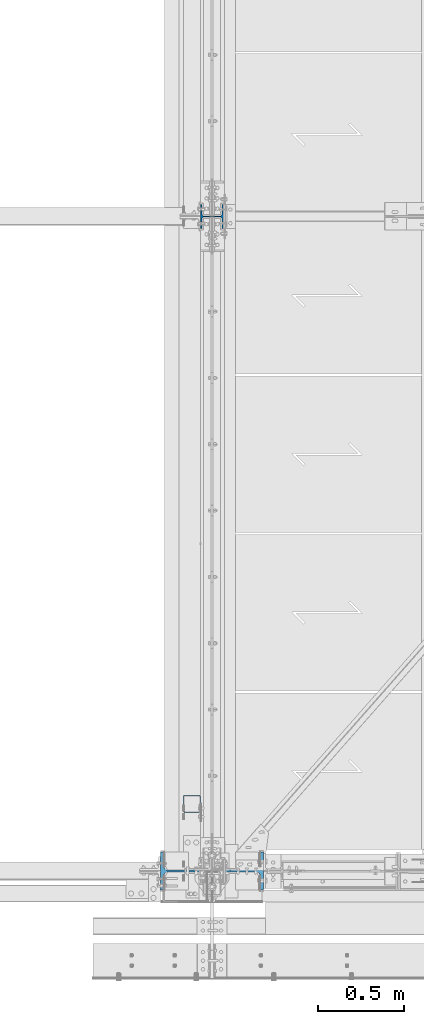
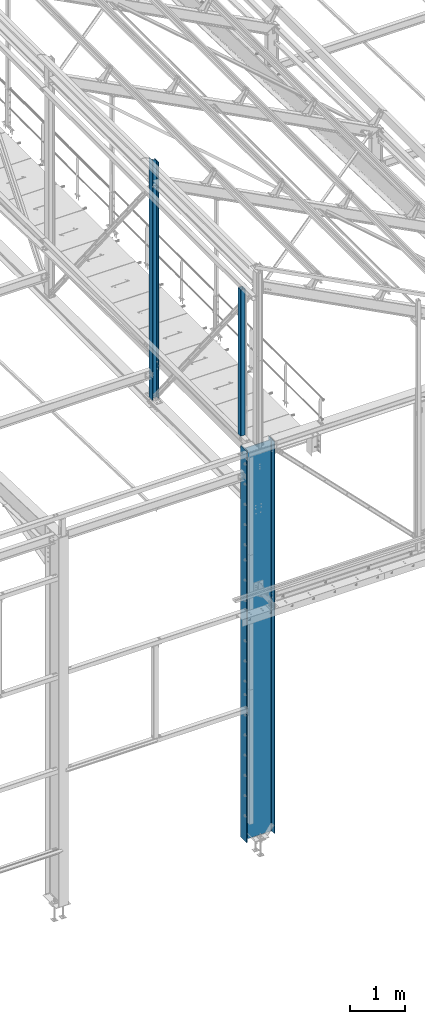
# One storey, part 3 of 496: 3 columns, 3 elements without a shape of their own.
"""IFC2X3 building model written with IfcOpenShell, lengths in millimetres."""

import ifcopenshell
import ifcopenshell.guid

model = None  # the IFC model being written
_history = None  # IfcOwnerHistory: only IFC2X3 demands one
_inside = {}  # id of a spatial element -> (the spatial element, [elements in it])
_under = {}  # id of a project, library or spatial element -> (it, [spatial elements below it])
_declared = {}  # id of a project -> (the project, [libraries it declares])
_typed = {}  # id of a type object -> (the type object, [elements of that type])
_made_of = {}  # id of a material, layer set ... -> (it, [elements and type objects made of it])


def new_model(schema):
    """Start an empty IFC model of exactly this schema.

    Asked for "IFC4X3", IfcOpenShell would pick the latest addendum, in which some entities
    have other attributes; the version numbers below select the first issue.
    IFC2X3 requires an IfcOwnerHistory on every rooted entity: one is made here for all.
    """
    global model, _history
    if schema == "IFC4X3":
        model = ifcopenshell.file(schema_version=(4, 3, 0, 0))
    else:
        model = ifcopenshell.file(schema=schema)
    _inside.clear()
    _under.clear()
    _declared.clear()
    _typed.clear()
    _made_of.clear()
    _history = None
    if model.schema == "IFC2X3":
        org = make("IfcOrganization", Name="unknown")
        user = make(
            "IfcPersonAndOrganization",
            ThePerson=make("IfcPerson", FamilyName="unknown"),
            TheOrganization=org,
        )
        app = make(
            "IfcApplication",
            ApplicationDeveloper=org,
            Version="unknown",
            ApplicationFullName="unknown",
            ApplicationIdentifier="unknown",
        )
        _history = make(
            "IfcOwnerHistory",
            OwningUser=user,
            OwningApplication=app,
            ChangeAction="ADDED",
            CreationDate=0,
        )
    return model


def make(cls, **values):
    """One entity of the class cls with the attributes given. An attribute that is None is left unset."""
    return model.create_entity(
        cls, **{name: value for name, value in values.items() if value is not None}
    )


def rooted(cls, **values):
    """An entity with a GlobalId (a new one), such as an element, a storey or a relation."""
    return make(cls, GlobalId=ifcopenshell.guid.new(), OwnerHistory=_history, **values)


def si_unit(unit_type, name, prefix=None):
    """IfcSIUnit, for example si_unit("LENGTHUNIT", "METRE", prefix="MILLI")."""
    return make("IfcSIUnit", UnitType=unit_type, Prefix=prefix, Name=name)


def assignment(units):
    """IfcUnitAssignment: the units of a project."""
    return None if units is None else make("IfcUnitAssignment", Units=units)


def point(xyz):
    """IfcCartesianPoint."""
    return None if xyz is None else make("IfcCartesianPoint", Coordinates=xyz)


def direction(xyz):
    """IfcDirection."""
    return None if xyz is None else make("IfcDirection", DirectionRatios=xyz)


def frame(location, z_axis=None, x_axis=None):
    """IfcAxis2Placement3D, a coordinate frame: its origin and axes. An axis left out is left unset."""
    return make(
        "IfcAxis2Placement3D",
        Location=point(location),
        Axis=direction(z_axis),
        RefDirection=direction(x_axis),
    )


def frame_2d(location, x_axis=None):
    """IfcAxis2Placement2D, a coordinate frame in the plane: its origin and x axis."""
    return make(
        "IfcAxis2Placement2D", Location=point(location), RefDirection=direction(x_axis)
    )


def origin_with_axes():
    """The frame at (0, 0, 0) with the z axis (0, 0, 1) and the x axis (1, 0, 0) written out."""
    return frame((0.0, 0.0, 0.0), z_axis=(0.0, 0.0, 1.0), x_axis=(1.0, 0.0, 0.0))


def origin_2d_with_axis():
    """The frame at (0, 0) in the plane with the x axis (1, 0) written out."""
    return frame_2d((0.0, 0.0), x_axis=(1.0, 0.0))


def place(relative_to, where):
    """IfcLocalPlacement: puts the frame where relative to a parent placement (None: the world)."""
    return make(
        "IfcLocalPlacement", PlacementRelTo=relative_to, RelativePlacement=where
    )


def context(
    kind, dimensions, precision=None, world=None, true_north=None, identifier=None
):
    """IfcGeometricRepresentationContext, for example the 3D "Model" context."""
    return make(
        "IfcGeometricRepresentationContext",
        ContextIdentifier=identifier,
        ContextType=kind,
        CoordinateSpaceDimension=dimensions,
        Precision=precision,
        WorldCoordinateSystem=world,
        TrueNorth=true_north,
    )


def subcontext(parent, identifier, kind, view, scale=None):
    """IfcGeometricRepresentationSubContext, for example "Body" below "Model"."""
    return make(
        "IfcGeometricRepresentationSubContext",
        ContextIdentifier=identifier,
        ContextType=kind,
        ParentContext=parent,
        TargetScale=scale,
        TargetView=view,
    )


def project(units=None, contexts=None):
    """IfcProject with its units and contexts."""
    return rooted(
        "IfcProject",
        Name="project",
        RepresentationContexts=contexts,
        UnitsInContext=assignment(units),
    )


def spatial(cls, under=None, at=None, **own):
    """A site, building, storey or space (cls), placed at a placement, below another one or the project."""
    s = rooted(cls, ObjectPlacement=at, **own)
    if under is not None:
        _under.setdefault(under.id(), (under, []))[1].append(s)
    return s


def profile(cls, at=None, kind="AREA", **sizes):
    """A parametric profile (cls). Its sizes go by their IFC names, for example OverallWidth=200.0."""
    return make(cls, ProfileType=kind, Position=at, **sizes)


def hollow_rectangle(**sizes):
    """IfcRectangleHollowProfileDef."""
    return profile("IfcRectangleHollowProfileDef", **sizes)


def i_section(**sizes):
    """IfcIShapeProfileDef."""
    return profile("IfcIShapeProfileDef", **sizes)


def extrude(swept, where, along, depth):
    """IfcExtrudedAreaSolid: the profile swept, set in the frame where, extruded along a direction by depth."""
    return make(
        "IfcExtrudedAreaSolid",
        SweptArea=swept,
        Position=where,
        ExtrudedDirection=direction(along),
        Depth=depth,
    )


def clip(a, b, op="DIFFERENCE"):
    """IfcBooleanClippingResult: the solid a cut by the half space b."""
    return make(
        "IfcBooleanClippingResult", Operator=op, FirstOperand=a, SecondOperand=b
    )


def halfspace(plane, agree):
    """IfcHalfSpaceSolid: all space on one side of the plane z = 0 of the frame plane."""
    return make(
        "IfcHalfSpaceSolid",
        BaseSurface=make("IfcPlane", Position=plane),
        AgreementFlag=agree,
    )


def shape(context_of_items, identifier, shape_type, items):
    """IfcShapeRepresentation: the items that make up one representation, for example the "Body"."""
    return make(
        "IfcShapeRepresentation",
        ContextOfItems=context_of_items,
        RepresentationIdentifier=identifier,
        RepresentationType=shape_type,
        Items=items,
    )


def material(Name=None, Category=None):
    """IfcMaterial."""
    return make("IfcMaterial", Name=Name, Category=Category)


def made_of(thing, what):
    """Note that an element or type object is made of a material, layer set ...; save() writes the relation."""
    if what is not None:
        _made_of.setdefault(what.id(), (what, []))[1].append(thing)
    return thing


def type_object(cls, material=None, **own):
    """A type object (cls), such as IfcWallType, which elements share."""
    return made_of(rooted(cls, **own), material)


def element(
    cls,
    number,
    at=None,
    inside=None,
    cuts=None,
    type_object=None,
    material=None,
    context=None,
    identifier="Body",
    shape_type=None,
    held_by="IfcProductDefinitionShape",
    body=None,
    shapes=None,
    **own,
):
    """One element of the class cls, such as IfcWall. Its Tag is "e" and its number.

    at: its placement. inside: the storey or other place that contains it. cuts: it is an
    opening in that element (IfcRelVoidsElement). A single representation is given by context,
    identifier, shape_type and body (its items); several are given by shapes. held_by: the class
    of the entity that holds the representations. save() writes the other relations.
    """
    e = rooted(cls, Tag="e%d" % number, ObjectPlacement=at, **own)
    if body is not None:
        shapes = [shape(context, identifier, shape_type, body)]
    if shapes is not None:
        e.Representation = make(held_by, Representations=shapes)
    if inside is not None:
        _inside.setdefault(inside.id(), (inside, []))[1].append(e)
    if cuts is not None:
        rooted(
            "IfcRelVoidsElement", RelatingBuildingElement=cuts, RelatedOpeningElement=e
        )
    if type_object is not None:
        _typed.setdefault(type_object.id(), (type_object, []))[1].append(e)
    return made_of(e, material)


def aggregate(whole, parts):
    """IfcRelAggregates: a whole, such as a stair, and the parts it consists of."""
    return rooted("IfcRelAggregates", RelatingObject=whole, RelatedObjects=parts)


def save(model, path):
    """Write the relations noted so far, then the file.

    IfcRelAggregates (storeys below a building ...), IfcRelContainedInSpatialStructure (elements
    in a storey), IfcRelDefinesByType, IfcRelAssociatesMaterial and IfcRelDeclares: one each for
    every whole, place, type object, material and project.
    """
    for whole, parts in _under.values():
        aggregate(whole, parts)
    for where, things in _inside.values():
        rooted(
            "IfcRelContainedInSpatialStructure",
            RelatedElements=things,
            RelatingStructure=where,
        )
    for kind, things in _typed.values():
        rooted("IfcRelDefinesByType", RelatedObjects=things, RelatingType=kind)
    for what, things in _made_of.values():
        rooted("IfcRelAssociatesMaterial", RelatedObjects=things, RelatingMaterial=what)
    for by, libraries in _declared.values():
        rooted("IfcRelDeclares", RelatingContext=by, RelatedDefinitions=libraries)
    model.write(path)


model = new_model("IFC2X3")

# Units and contexts
model_context = context("Model", 3, precision=1e-05, world=origin_with_axes())
body_context = subcontext(model_context, "Body", "Model", "MODEL_VIEW")
ifc_project = project(units=[si_unit("LENGTHUNIT", "METRE", prefix="MILLI"), si_unit("AREAUNIT", "SQUARE_METRE"), si_unit("VOLUMEUNIT", "CUBIC_METRE"), si_unit("MASSUNIT", "GRAM", prefix="KILO"), si_unit("TIMEUNIT", "SECOND"), si_unit("PLANEANGLEUNIT", "RADIAN"), si_unit("SOLIDANGLEUNIT", "STERADIAN"), si_unit("THERMODYNAMICTEMPERATUREUNIT", "DEGREE_CELSIUS"), si_unit("LUMINOUSINTENSITYUNIT", "LUMEN")], contexts=[model_context])

# Site, building, storey
site_placement = place(None, origin_with_axes())
site = spatial("IfcSite", under=ifc_project, at=site_placement, CompositionType="ELEMENT")
building_placement = place(site_placement, origin_with_axes())
building = spatial("IfcBuilding", under=site, at=building_placement, Name="Undefined", CompositionType="ELEMENT")
storey_placement = place(building_placement, origin_with_axes())
storey = spatial("IfcBuildingStorey", under=building, at=storey_placement, Name="Undefined", CompositionType="ELEMENT", Elevation=0.0)

# Assembly, column
assembly_1_placement = place(storey_placement, origin_with_axes())
assembly_1 = element("IfcElementAssembly", 1, at=assembly_1_placement, inside=storey, Name="MONTANT", AssemblyPlace="NOTDEFINED", PredefinedType="NOTDEFINED")
ifc_material_1 = material(Name="Undefined/S235-E24")
column_type_1 = type_object("IfcColumnType", PredefinedType="NOTDEFINED")
column_1_placement = place(assembly_1_placement, frame((12563.5001162733, 389.9999987911, 8555.00000000001), z_axis=(0.0, 0.0, 1.0), x_axis=(0.0, -1.0, 0.0)))
column_1 = element("IfcColumn", 2, at=column_1_placement, type_object=column_type_1, material=ifc_material_1, Name="MONTANT", context=body_context, shape_type="SweptSolid", body=[
    extrude(hollow_rectangle(XDim=100.0, YDim=100.0, WallThickness=4.0, InnerFilletRadius=4.0, OuterFilletRadius=8.0, at=origin_2d_with_axis()), frame((0.0, 0.0, 3260.0), z_axis=(0.0, 0.0, -1.0), x_axis=(0.0, 1.0, 0.0)), (0.0, 0.0, 1.0), 3260.0),
])
aggregate(assembly_1, [column_1])

assembly_2_placement = place(storey_placement, origin_with_axes())
assembly_2 = element("IfcElementAssembly", 3, at=assembly_2_placement, inside=storey, Name="MONTANT", AssemblyPlace="NOTDEFINED", PredefinedType="NOTDEFINED")
ifc_material_2 = material(Name="Undefined/S275-E28")
column_type_2 = type_object("IfcColumnType", Name="HEA140", PredefinedType="NOTDEFINED")
column_2_placement = place(assembly_2_placement, frame((12680.0, 3800.0, 7260.0), z_axis=(0.0, 0.0, 1.0), x_axis=(-1.0, 0.0, 0.0)))
column_2 = element("IfcColumn", 4, at=column_2_placement, type_object=column_type_2, material=ifc_material_2, Name="MONTANT", ObjectType="HEA140", context=body_context, shape_type="Clipping", body=[
    clip(extrude(i_section(OverallWidth=140.0, OverallDepth=133.0, WebThickness=5.5, FlangeThickness=8.5, FilletRadius=12.0, at=origin_2d_with_axis()), frame((0.0, 0.0, 5353.83208547676), z_axis=(0.0, 0.0, -1.0), x_axis=(0.0, 1.0, 0.0)), (0.0, 0.0, 1.0), 5353.83), halfspace(frame((-66.5, 70.0, 5272.97130380653), z_axis=(-0.463528461042155, -7.08866187195592e-09, 0.886082031080583), x_axis=(0.886082031080583, 0.0, 0.463528461042155)), False)),
])
aggregate(assembly_2, [column_2])

assembly_3_placement = place(storey_placement, origin_with_axes())
assembly_3 = element("IfcElementAssembly", 5, at=assembly_3_placement, inside=storey, Name="POTEAU", AssemblyPlace="NOTDEFINED", PredefinedType="NOTDEFINED")
column_type_3 = type_object("IfcColumnType", Name="IPE600", PredefinedType="NOTDEFINED")
column_3_placement = place(assembly_3_placement, frame((12679.9971504447, 0.0, -185.0), z_axis=(0.0, 0.0, 1.0), x_axis=(-1.0, 0.0, 0.0)))
column_3 = element("IfcColumn", 6, at=column_3_placement, type_object=column_type_3, material=ifc_material_2, Name="POTEAU", ObjectType="IPE600", context=body_context, shape_type="SweptSolid", body=[
    extrude(i_section(OverallWidth=220.0, OverallDepth=600.0, WebThickness=12.0, FlangeThickness=19.0, FilletRadius=24.0, at=origin_2d_with_axis()), frame((-4.61897654049632e-19, 0.0, 8725.0000000004), z_axis=(0.0, 0.0, -1.0), x_axis=(0.0, 1.0, 0.0)), (0.0, 0.0, 1.0), 8725.0),
])
aggregate(assembly_3, [column_3])

save(model, "model.ifc")
